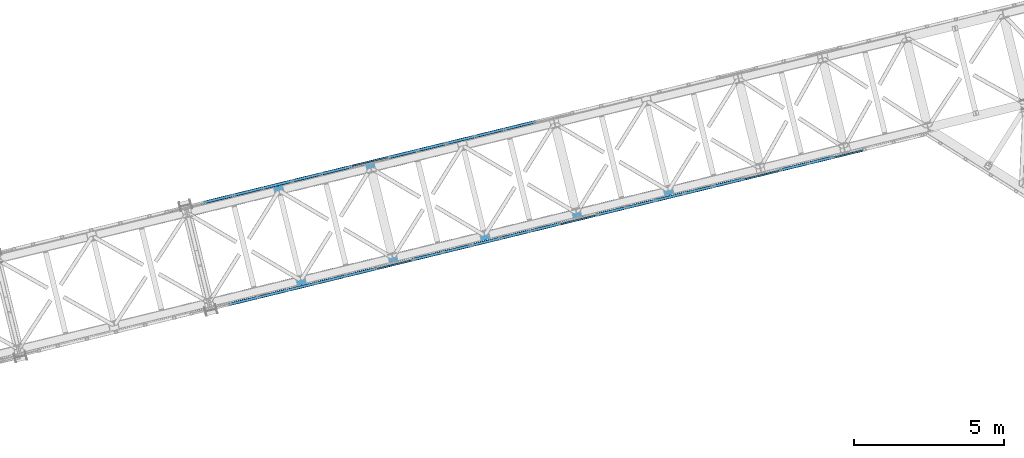
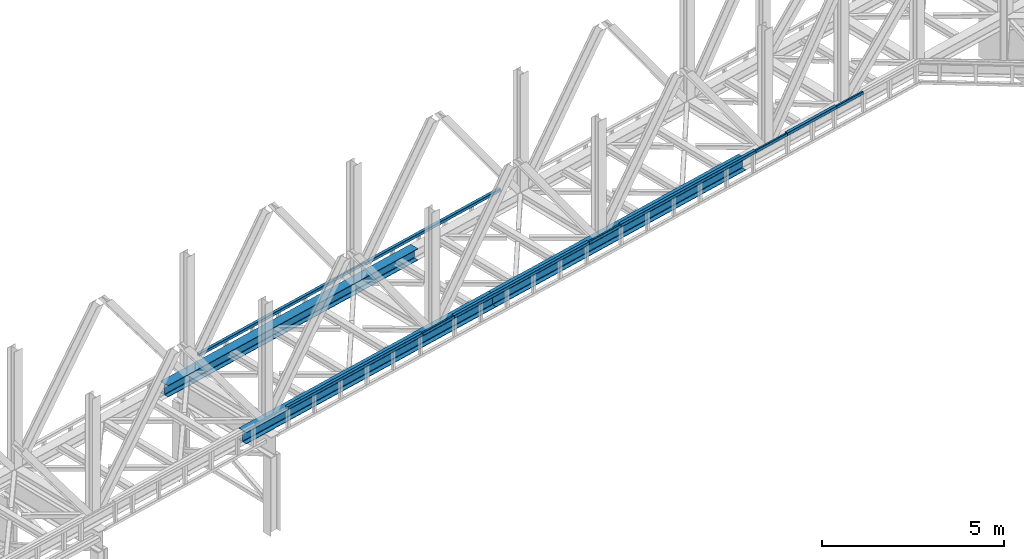
# One storey, part 18 of 93: 14 beams.
"""IFC4 building model written with IfcOpenShell, lengths in millimetres."""

import ifcopenshell
import ifcopenshell.guid

model = None  # the IFC model being written
_history = None  # IfcOwnerHistory: only IFC2X3 demands one
_inside = {}  # id of a spatial element -> (the spatial element, [elements in it])
_under = {}  # id of a project, library or spatial element -> (it, [spatial elements below it])
_declared = {}  # id of a project -> (the project, [libraries it declares])
_typed = {}  # id of a type object -> (the type object, [elements of that type])
_made_of = {}  # id of a material, layer set ... -> (it, [elements and type objects made of it])


def new_model(schema):
    """Start an empty IFC model of exactly this schema.

    Asked for "IFC4X3", IfcOpenShell would pick the latest addendum, in which some entities
    have other attributes; the version numbers below select the first issue.
    IFC2X3 requires an IfcOwnerHistory on every rooted entity: one is made here for all.
    """
    global model, _history
    if schema == "IFC4X3":
        model = ifcopenshell.file(schema_version=(4, 3, 0, 0))
    else:
        model = ifcopenshell.file(schema=schema)
    _inside.clear()
    _under.clear()
    _declared.clear()
    _typed.clear()
    _made_of.clear()
    _history = None
    if model.schema == "IFC2X3":
        org = make("IfcOrganization", Name="unknown")
        user = make(
            "IfcPersonAndOrganization",
            ThePerson=make("IfcPerson", FamilyName="unknown"),
            TheOrganization=org,
        )
        app = make(
            "IfcApplication",
            ApplicationDeveloper=org,
            Version="unknown",
            ApplicationFullName="unknown",
            ApplicationIdentifier="unknown",
        )
        _history = make(
            "IfcOwnerHistory",
            OwningUser=user,
            OwningApplication=app,
            ChangeAction="ADDED",
            CreationDate=0,
        )
    return model


def make(cls, **values):
    """One entity of the class cls with the attributes given. An attribute that is None is left unset."""
    return model.create_entity(
        cls, **{name: value for name, value in values.items() if value is not None}
    )


def entity(cls, *values):
    """Any entity or typed value of the class cls, its attributes in the order of the schema. None: left unset."""
    e = model.create_entity(cls)
    for i, value in enumerate(values):
        if value is not None:
            e[i] = value
    return e


def rooted(cls, **values):
    """An entity with a GlobalId (a new one), such as an element, a storey or a relation."""
    return make(cls, GlobalId=ifcopenshell.guid.new(), OwnerHistory=_history, **values)


def si_unit(unit_type, name, prefix=None):
    """IfcSIUnit, for example si_unit("LENGTHUNIT", "METRE", prefix="MILLI")."""
    return make("IfcSIUnit", UnitType=unit_type, Prefix=prefix, Name=name)


def converted_unit(unit_type, name, factor, base, dimensions=None, offset=None):
    """IfcConversionBasedUnit, such as the inch: factor (a typed value) times the base unit."""
    return make(
        "IfcConversionBasedUnit"
        if offset is None
        else "IfcConversionBasedUnitWithOffset",
        ConversionOffset=offset,
        Dimensions=None
        if dimensions is None
        else entity("IfcDimensionalExponents", *dimensions),
        UnitType=unit_type,
        Name=name,
        ConversionFactor=make(
            "IfcMeasureWithUnit", ValueComponent=factor, UnitComponent=base
        ),
    )


def derived_unit(unit_type, elements):
    """IfcDerivedUnit: a product of units, each with its exponent."""
    return make(
        "IfcDerivedUnit",
        Elements=[
            make("IfcDerivedUnitElement", Unit=unit, Exponent=power)
            for unit, power in elements
        ],
        UnitType=unit_type,
    )


def assignment(units):
    """IfcUnitAssignment: the units of a project."""
    return None if units is None else make("IfcUnitAssignment", Units=units)


def point(xyz):
    """IfcCartesianPoint."""
    return None if xyz is None else make("IfcCartesianPoint", Coordinates=xyz)


def direction(xyz):
    """IfcDirection."""
    return None if xyz is None else make("IfcDirection", DirectionRatios=xyz)


def frame(location, z_axis=None, x_axis=None):
    """IfcAxis2Placement3D, a coordinate frame: its origin and axes. An axis left out is left unset."""
    return make(
        "IfcAxis2Placement3D",
        Location=point(location),
        Axis=direction(z_axis),
        RefDirection=direction(x_axis),
    )


def origin():
    """The frame at (0, 0, 0) with its axes left unset."""
    return frame((0.0, 0.0, 0.0))


def place(relative_to, where):
    """IfcLocalPlacement: puts the frame where relative to a parent placement (None: the world)."""
    return make(
        "IfcLocalPlacement", PlacementRelTo=relative_to, RelativePlacement=where
    )


def context(
    kind, dimensions, precision=None, world=None, true_north=None, identifier=None
):
    """IfcGeometricRepresentationContext, for example the 3D "Model" context."""
    return make(
        "IfcGeometricRepresentationContext",
        ContextIdentifier=identifier,
        ContextType=kind,
        CoordinateSpaceDimension=dimensions,
        Precision=precision,
        WorldCoordinateSystem=world,
        TrueNorth=true_north,
    )


def subcontext(parent, identifier, kind, view, scale=None):
    """IfcGeometricRepresentationSubContext, for example "Body" below "Model"."""
    return make(
        "IfcGeometricRepresentationSubContext",
        ContextIdentifier=identifier,
        ContextType=kind,
        ParentContext=parent,
        TargetScale=scale,
        TargetView=view,
    )


def project(units=None, contexts=None):
    """IfcProject with its units and contexts."""
    return rooted(
        "IfcProject",
        Name="project",
        RepresentationContexts=contexts,
        UnitsInContext=assignment(units),
    )


def spatial(cls, under=None, at=None, **own):
    """A site, building, storey or space (cls), placed at a placement, below another one or the project."""
    s = rooted(cls, ObjectPlacement=at, **own)
    if under is not None:
        _under.setdefault(under.id(), (under, []))[1].append(s)
    return s


def point_list(points):
    """IfcCartesianPointList2D or 3D."""
    cls = (
        "IfcCartesianPointList2D" if len(points[0]) == 2 else "IfcCartesianPointList3D"
    )
    return make(cls, CoordList=points)


def indexed_curve(points, segments=None, self_intersect=None):
    """IfcIndexedPolyCurve: lines and arcs through numbered points (the first is 1)."""
    return make(
        "IfcIndexedPolyCurve",
        Points=point_list(points),
        Segments=segments,
        SelfIntersect=self_intersect,
    )


def outline(outer, holes=None, kind="AREA"):
    """IfcArbitraryClosedProfileDef: a profile drawn as a closed curve; with holes, ...WithVoids."""
    if holes is None:
        return make("IfcArbitraryClosedProfileDef", ProfileType=kind, OuterCurve=outer)
    return make(
        "IfcArbitraryProfileDefWithVoids",
        ProfileType=kind,
        OuterCurve=outer,
        InnerCurves=holes,
    )


def extrude(swept, where, along, depth):
    """IfcExtrudedAreaSolid: the profile swept, set in the frame where, extruded along a direction by depth."""
    return make(
        "IfcExtrudedAreaSolid",
        SweptArea=swept,
        Position=where,
        ExtrudedDirection=direction(along),
        Depth=depth,
    )


def shape(context_of_items, identifier, shape_type, items):
    """IfcShapeRepresentation: the items that make up one representation, for example the "Body"."""
    return make(
        "IfcShapeRepresentation",
        ContextOfItems=context_of_items,
        RepresentationIdentifier=identifier,
        RepresentationType=shape_type,
        Items=items,
    )


def material(Name=None, Category=None):
    """IfcMaterial."""
    return make("IfcMaterial", Name=Name, Category=Category)


def made_of(thing, what):
    """Note that an element or type object is made of a material, layer set ...; save() writes the relation."""
    if what is not None:
        _made_of.setdefault(what.id(), (what, []))[1].append(thing)
    return thing


def type_object(cls, material=None, **own):
    """A type object (cls), such as IfcWallType, which elements share."""
    return made_of(rooted(cls, **own), material)


def element(
    cls,
    number,
    at=None,
    inside=None,
    cuts=None,
    type_object=None,
    material=None,
    context=None,
    identifier="Body",
    shape_type=None,
    held_by="IfcProductDefinitionShape",
    body=None,
    shapes=None,
    **own,
):
    """One element of the class cls, such as IfcWall. Its Tag is "e" and its number.

    at: its placement. inside: the storey or other place that contains it. cuts: it is an
    opening in that element (IfcRelVoidsElement). A single representation is given by context,
    identifier, shape_type and body (its items); several are given by shapes. held_by: the class
    of the entity that holds the representations. save() writes the other relations.
    """
    e = rooted(cls, Tag="e%d" % number, ObjectPlacement=at, **own)
    if body is not None:
        shapes = [shape(context, identifier, shape_type, body)]
    if shapes is not None:
        e.Representation = make(held_by, Representations=shapes)
    if inside is not None:
        _inside.setdefault(inside.id(), (inside, []))[1].append(e)
    if cuts is not None:
        rooted(
            "IfcRelVoidsElement", RelatingBuildingElement=cuts, RelatedOpeningElement=e
        )
    if type_object is not None:
        _typed.setdefault(type_object.id(), (type_object, []))[1].append(e)
    return made_of(e, material)


def aggregate(whole, parts):
    """IfcRelAggregates: a whole, such as a stair, and the parts it consists of."""
    return rooted("IfcRelAggregates", RelatingObject=whole, RelatedObjects=parts)


def save(model, path):
    """Write the relations noted so far, then the file.

    IfcRelAggregates (storeys below a building ...), IfcRelContainedInSpatialStructure (elements
    in a storey), IfcRelDefinesByType, IfcRelAssociatesMaterial and IfcRelDeclares: one each for
    every whole, place, type object, material and project.
    """
    for whole, parts in _under.values():
        aggregate(whole, parts)
    for where, things in _inside.values():
        rooted(
            "IfcRelContainedInSpatialStructure",
            RelatedElements=things,
            RelatingStructure=where,
        )
    for kind, things in _typed.values():
        rooted("IfcRelDefinesByType", RelatedObjects=things, RelatingType=kind)
    for what, things in _made_of.values():
        rooted("IfcRelAssociatesMaterial", RelatedObjects=things, RelatingMaterial=what)
    for by, libraries in _declared.values():
        rooted("IfcRelDeclares", RelatingContext=by, RelatedDefinitions=libraries)
    model.write(path)


model = new_model("IFC4")

# Units and contexts
model_context = context("Model", 3, precision=0.01, world=origin(), true_north=direction((6.12303176911189e-17, 1.0)))
plan_context = context("Plan", 3, precision=0.01, world=origin(), true_north=direction((6.12303176911189e-17, 1.0)))
body_context = subcontext(model_context, "Body", "Model", "MODEL_VIEW")
ifc_project = project(units=[si_unit("LENGTHUNIT", "METRE", prefix="MILLI"), si_unit("AREAUNIT", "SQUARE_METRE"), si_unit("VOLUMEUNIT", "CUBIC_METRE"), converted_unit("PLANEANGLEUNIT", "DEGREE", entity("IfcRatioMeasure", 0.0174532925199433), si_unit("PLANEANGLEUNIT", "RADIAN"), dimensions=[0, 0, 0, 0, 0, 0, 0]), si_unit("MASSUNIT", "GRAM", prefix="KILO"), derived_unit("MASSDENSITYUNIT", [(si_unit("MASSUNIT", "GRAM", prefix="KILO"), 1), (si_unit("LENGTHUNIT", "METRE"), -3)]), derived_unit("MOMENTOFINERTIAUNIT", [(si_unit("LENGTHUNIT", "METRE"), 4)]), si_unit("TIMEUNIT", "SECOND"), si_unit("FREQUENCYUNIT", "HERTZ"), si_unit("THERMODYNAMICTEMPERATUREUNIT", "DEGREE_CELSIUS"), derived_unit("THERMALTRANSMITTANCEUNIT", [(si_unit("MASSUNIT", "GRAM", prefix="KILO"), 1), (si_unit("THERMODYNAMICTEMPERATUREUNIT", "KELVIN"), -1), (si_unit("TIMEUNIT", "SECOND"), -3)]), derived_unit("VOLUMETRICFLOWRATEUNIT", [(si_unit("LENGTHUNIT", "METRE"), 3), (si_unit("TIMEUNIT", "SECOND"), -1)]), derived_unit("MASSFLOWRATEUNIT", [(si_unit("MASSUNIT", "GRAM", prefix="KILO"), 1), (si_unit("TIMEUNIT", "SECOND"), -1)]), derived_unit("ROTATIONALFREQUENCYUNIT", [(si_unit("TIMEUNIT", "SECOND"), -1)]), si_unit("ELECTRICCURRENTUNIT", "AMPERE"), si_unit("ELECTRICVOLTAGEUNIT", "VOLT"), si_unit("POWERUNIT", "WATT"), si_unit("FORCEUNIT", "NEWTON", prefix="KILO"), si_unit("ILLUMINANCEUNIT", "LUX"), si_unit("LUMINOUSFLUXUNIT", "LUMEN"), si_unit("LUMINOUSINTENSITYUNIT", "CANDELA"), derived_unit("USERDEFINED", [(si_unit("MASSUNIT", "GRAM", prefix="KILO"), -1), (si_unit("LENGTHUNIT", "METRE"), -2), (si_unit("TIMEUNIT", "SECOND"), 3), (si_unit("LUMINOUSFLUXUNIT", "LUMEN"), 1)]), derived_unit("LINEARVELOCITYUNIT", [(si_unit("LENGTHUNIT", "METRE"), 1), (si_unit("TIMEUNIT", "SECOND"), -1)]), si_unit("PRESSUREUNIT", "PASCAL"), derived_unit("USERDEFINED", [(si_unit("LENGTHUNIT", "METRE"), -2), (si_unit("MASSUNIT", "GRAM", prefix="KILO"), 1), (si_unit("TIMEUNIT", "SECOND"), -2)]), derived_unit("LINEARFORCEUNIT", [(si_unit("MASSUNIT", "GRAM", prefix="KILO"), 1), (si_unit("LENGTHUNIT", "METRE"), 1), (si_unit("TIMEUNIT", "SECOND"), -2), (si_unit("LENGTHUNIT", "METRE"), -1)]), derived_unit("PLANARFORCEUNIT", [(si_unit("MASSUNIT", "GRAM", prefix="KILO"), 1), (si_unit("LENGTHUNIT", "METRE"), 1), (si_unit("TIMEUNIT", "SECOND"), -2), (si_unit("LENGTHUNIT", "METRE"), -2)])], contexts=[model_context, plan_context])

# Site, building, storey
site_placement = place(None, origin())
site = spatial("IfcSite", under=ifc_project, at=site_placement, CompositionType="ELEMENT")
building_placement = place(site_placement, origin())
building = spatial("IfcBuilding", under=site, at=building_placement, CompositionType="ELEMENT")
storey_placement = place(building_placement, frame((0.0, 0.0, 15900.0)))
storey = spatial("IfcBuildingStorey", under=building, at=storey_placement, CompositionType="ELEMENT", Elevation=15900.0)

# Beams
ifc_material = material(Name="Metal painted (White)")
beam_type = type_object("IfcBeamType", PredefinedType="BEAM")
beam_1_placement = place(storey_placement, origin())
element("IfcBeam", 1, at=beam_1_placement, inside=storey, type_object=beam_type, material=ifc_material, ObjectType="Steel Beam", PredefinedType="BEAM", context=body_context, shape_type="SweptSolid", body=[
    extrude(outline(indexed_curve([(-195.999999999999, -150.000000000005), (-179.999999999996, -150.000000000005), (-179.999999999996, -27.7500000000041), (-178.325349715245, -19.3309644879734), (-173.556349186101, -12.1936508138996), (-166.419035512029, -7.42465028475491), (-157.999999999997, -5.75000000000425), (158.000000000005, -5.75000000000425), (166.419035512033, -7.42465028475491), (173.556349186107, -12.1936508138996), (178.325349715251, -19.3309644879734), (180.0, -27.7500000000041), (180.0, -150.000000000005), (196.000000000005, -150.000000000005), (196.000000000005, 149.999999999996), (180.0, 149.999999999996), (180.0, 27.7499999999947), (178.325349715251, 19.3309644879649), (173.556349186107, 12.1936508138912), (166.419035512033, 7.42465028474757), (158.000000000005, 5.74999999999584), (-157.999999999997, 5.74999999999373), (-166.419035512029, 7.42465028474757), (-173.556349186101, 12.1936508138912), (-178.325349715245, 19.3309644879618), (-179.999999999996, 27.7499999999968), (-179.999999999996, 149.999999999994), (-195.999999999999, 149.999999999996), (-195.999999999999, -150.000000000005)], self_intersect=False)), frame((-30278.9740146601, 10220.7567522767, 3489.0), z_axis=(0.971552058141469, 0.236826092990355, 0.0), x_axis=(0.0, 0.0, 1.0)), (0.0, 0.0, 1.0), 9480.00000000004),
])
beam_2_placement = place(storey_placement, origin())
element("IfcBeam", 2, at=beam_2_placement, inside=storey, type_object=beam_type, material=ifc_material, ObjectType="Steel Beam", PredefinedType="BEAM", context=body_context, shape_type="SweptSolid", body=[
    extrude(outline(indexed_curve([(-195.999999999999, -150.000000000003), (-179.999999999996, -150.000000000003), (-179.999999999996, -27.750000000002), (-178.325349715245, -19.3309644879713), (-173.556349186101, -12.1936508138975), (-166.419035512029, -7.4246502847528), (-157.999999999997, -5.75000000000215), (158.000000000005, -5.75000000000215), (166.419035512033, -7.4246502847528), (173.556349186107, -12.1936508138975), (178.325349715251, -19.3309644879713), (180.0, -27.750000000002), (180.0, -150.000000000003), (196.000000000005, -150.000000000003), (196.000000000005, 149.999999999996), (180.0, 149.999999999996), (180.0, 27.7499999999947), (178.325349715251, 19.330964487967), (173.556349186107, 12.1936508138912), (166.419035512033, 7.42465028474967), (158.000000000005, 5.74999999999584), (-157.999999999997, 5.74999999999584), (-166.419035512029, 7.42465028474967), (-173.556349186101, 12.1936508138933), (-178.325349715245, 19.330964487967), (-179.999999999996, 27.7499999999999), (-179.999999999996, 149.999999999996), (-195.999999999999, 149.999999999996), (-195.999999999999, -150.000000000003)], self_intersect=False)), frame((-21068.6605034789, 12465.8681138251, 3489.0), z_axis=(0.971552058141469, 0.236826092990355, 0.0), x_axis=(0.0, 0.0, 1.0)), (0.0, 0.0, 1.0), 9479.99999999997),
])
beam_3_placement = place(storey_placement, origin())
element("IfcBeam", 3, at=beam_3_placement, inside=storey, type_object=beam_type, material=ifc_material, ObjectType="Steel Beam", PredefinedType="BEAM", context=body_context, shape_type="SweptSolid", body=[
    extrude(outline(indexed_curve([(-195.999999999999, -150.000000000001), (-179.999999999996, -150.000000000001), (-179.999999999996, -27.7499999999999), (-178.325349715245, -19.3309644879691), (-173.556349186101, -12.1936508138954), (-166.419035512029, -7.4246502847528), (-157.999999999997, -5.75000000000005), (158.000000000005, -5.75000000000005), (166.419035512033, -7.4246502847528), (173.556349186107, -12.1936508138954), (178.325349715251, -19.3309644879691), (180.0, -27.7499999999999), (180.0, -150.000000000001), (196.000000000005, -150.000000000001), (196.000000000005, 149.999999999998), (180.0, 149.999999999998), (180.0, 27.7499999999968), (178.325349715251, 19.3309644879691), (173.556349186107, 12.1936508138933), (166.419035512033, 7.4246502847528), (158.000000000005, 5.74999999999794), (-157.999999999997, 5.74999999999584), (-166.419035512029, 7.42465028474757), (-173.556349186101, 12.1936508138933), (-178.325349715247, 19.330964487967), (-179.999999999996, 27.7499999999968), (-179.999999999996, 149.999999999996), (-195.999999999999, 149.999999999998), (-195.999999999999, -150.000000000001)], self_intersect=False)), frame((-31013.1349029302, 13232.5681325153, 3489.0), z_axis=(0.971552058141469, 0.236826092990355, 0.0), x_axis=(0.0, 0.0, 1.0)), (0.0, 0.0, 1.0), 9480.00000000004),
])
beam_4_placement = place(storey_placement, origin())
element("IfcBeam", 4, at=beam_4_placement, inside=storey, type_object=beam_type, material=ifc_material, ObjectType="Steel Beam", PredefinedType="BEAM", context=body_context, shape_type="SweptSolid", body=[
    extrude(outline(indexed_curve([(29.4768951153319, -56.8428769008003), (33.3787015556544, -56.8428769008003), (36.9835006656888, -55.3497202197897), (39.7424944585191, -52.5907264269642), (41.2356511395258, -48.9859273169303), (56.8428769008051, 29.4768951153294), (56.8428769008049, 33.3787015556509), (55.3497202197946, 36.9835006656864), (52.5907264269671, 39.7424944585227), (48.9859273169311, 41.2356511395243), (-29.476895115329, 56.8428769008041), (-33.3787015556507, 56.8428769008084), (-36.9835006656858, 55.3497202197935), (-39.742494458517, 52.5907264269638), (-41.2356511395237, 48.9859273169299), (-56.8428769008031, -29.4768951153298), (-56.8428769008019, -33.3787015556515), (-55.3497202197906, -36.9835006656828), (-52.5907264269633, -39.7424944585146), (-48.9859273169282, -41.2356511395205), (29.4768951153319, -56.8428769008003)], self_intersect=False), holes=[indexed_curve([(-50.9634988887046, -25.5484203233951), (-37.3071763475817, 43.1065493048336), (-35.8140196665771, 46.7113484148679), (-33.0550258737489, 49.4703422076983), (-29.4502267637103, 50.9634988887036), (-25.5484203233909, 50.9634988887042), (43.1065493048361, 37.3071763475801), (46.7113484148721, 35.8140196665785), (49.4703422077023, 33.0550258737505), (50.9634988887086, 29.4502267637158), (50.9634988887087, 25.5484203233943), (37.3071763475889, -43.1065493048351), (35.8140196665843, -46.7113484148694), (33.055025873758, -49.4703422076957), (29.4502267637217, -50.9634988887059), (25.5484203233971, -50.9634988887055), (-43.1065493048287, -37.307176347586), (-46.7113484148688, -35.8140196665836), (-49.4703422076953, -33.0550258737475), (-50.9634988887024, -29.450226763717), (-50.9634988887046, -25.5484203233951)], self_intersect=False)]), frame((-23487.2518283155, 15272.9379390032, 3830.0), z_axis=(0.971552058141621, 0.236826092989728, 0.0), x_axis=(0.232275546019843, -0.952883957770766, -0.195090322015997)), (0.0, 0.0, 1.0), 5120.00000000002),
])
beam_5_placement = place(storey_placement, origin())
element("IfcBeam", 5, at=beam_5_placement, inside=storey, type_object=beam_type, material=ifc_material, ObjectType="Steel Beam", PredefinedType="BEAM", context=body_context, shape_type="SweptSolid", body=[
    extrude(outline(indexed_curve([(29.4768951153935, -56.8428769007593), (33.3787015557151, -56.8428769007593), (36.983500665747, -55.349720219749), (39.742494458576, -52.590726426912), (41.2356511395787, -48.9859273168765), (56.8428769007747, 29.4768951153998), (56.8428769007672, 33.378701555722), (55.3497202197551, 36.983500665751), (52.5907264269217, 39.7424944585804), (48.985927316885, 41.2356511395824), (-29.4768951153901, 56.8428769007763), (-33.3787015557126, 56.842876900772), (-36.9835006657444, 55.3497202197617), (-39.7424944585747, 52.5907264269294), (-41.2356511395753, 48.9859273168935), (-56.8428769007713, -29.4768951153829), (-56.8428769007638, -33.378701555705), (-55.3497202197535, -36.9835006657425), (-52.5907264269192, -39.7424944585677), (-48.9859273168817, -41.2356511395654), (29.4768951153935, -56.8428769007593)], self_intersect=False), holes=[indexed_curve([(-50.9634988886751, -25.5484203234422), (-37.307176347631, 43.1065493048023), (-35.8140196666262, 46.7113484148374), (-33.055025873804, 49.4703422076669), (-29.4502267637722, 50.9634988886772), (-25.5484203234488, 50.9634988886857), (43.106549304796, 37.3071763476402), (46.7113484148319, 35.8140196666341), (49.470342207663, 33.0550258738095), (50.9634988886761, 29.4502267637803), (50.9634988886805, 25.5484203234587), (37.3071763476375, -43.1065493047859), (35.8140196666368, -46.7113484148218), (33.0550258738057, -49.4703422076584), (29.4502267637718, -50.9634988886683), (25.5484203234514, -50.963498888673), (-43.1065493047935, -37.3071763476275), (-46.7113484148302, -35.8140196666256), (-49.4703422076655, -33.0550258738002), (-50.9634988886707, -29.4502267637637), (-50.9634988886751, -25.5484203234422)], self_intersect=False)]), frame((-29627.4608357696, 13776.1970313043, 3830.0), z_axis=(0.971552058141621, 0.236826092989728, 0.0), x_axis=(0.232275546019893, -0.952883957770972, -0.19509032201493)), (0.0, 0.0, 1.0), 5119.99999999998),
])
beam_6_placement = place(storey_placement, origin())
element("IfcBeam", 6, at=beam_6_placement, inside=storey, type_object=beam_type, material=ifc_material, ObjectType="Steel Beam", PredefinedType="BEAM", context=body_context, shape_type="SweptSolid", body=[
    extrude(outline(indexed_curve([(9.86118950714156, -52.9410704605108), (13.7629959474637, -52.9410704605108), (17.3677950575018, -51.4479137795173), (20.1267888503371, -48.688919986689), (21.619945531354, -45.0841208766589), (37.2271712928117, 33.3787015555653), (37.2271712928194, 37.280507995887), (35.7340146118204, 40.8853071059253), (32.9750208189955, 43.6443008987598), (29.3702217089667, 45.1374575797777), (-9.8611895071486, 52.9410704605078), (-13.7629959474699, 52.941070460512), (-17.3677950575068, 51.4479137795139), (-20.1267888503412, 48.6889199866898), (-21.6199455313581, 45.0841208766597), (-37.2271712928179, -33.3787015555641), (-37.2271712928236, -37.2805079958862), (-35.7340146118264, -40.8853071059285), (-32.9750208190027, -43.6443008987584), (-29.3702217089748, -45.1374575797806), (9.86118950714156, -52.9410704605108)], self_intersect=False), holes=[indexed_curve([(-31.3477932807115, -29.4502267636426), (-17.6914707394336, 39.2047428645554), (-16.1983140584188, 42.8095419745858), (-13.4393202655864, 45.5685357674103), (-9.83452115554951, 47.0616924484085), (-5.93271471522702, 47.0616924483995), (23.4908436968574, 41.2089827878524), (27.0956428068891, 39.7158261068383), (29.854636599712, 36.9568323140043), (31.3477932807151, 33.3520332039651), (31.3477932807074, 29.4502267636434), (17.6914707394295, -39.2047428645545), (16.1983140584126, -42.8095419745846), (13.4393202655773, -45.5685357674129), (9.83452115554126, -47.0616924484068), (5.93271471521876, -47.0616924483979), (-23.4908436968687, -41.2089827878502), (-27.0956428068983, -39.7158261068365), (-29.85463659972, -36.9568323140071), (-31.3477932807192, -33.3520332039643), (-31.3477932807115, -29.4502267636426)], self_intersect=False)]), frame((-24657.5843905905, 15007.0846725123, 3830.0), z_axis=(0.97155205814156, 0.236826092989979, 0.0), x_axis=(-0.232275546019865, 0.952883957770302, 0.195090322018236)), (0.0, 0.0, 1.0), 1200.00000000001),
])
beam_7_placement = place(storey_placement, origin())
element("IfcBeam", 7, at=beam_7_placement, inside=storey, type_object=beam_type, material=ifc_material, ObjectType="Steel Beam", PredefinedType="BEAM", context=body_context, shape_type="SweptSolid", body=[
    extrude(outline(indexed_curve([(29.4768951153359, -56.8428769008), (33.3787015556589, -56.8428769008), (36.9835006656937, -55.3497202197894), (39.7424944585219, -52.5907264269634), (41.2356511395285, -48.9859273169295), (56.8428769008057, 29.4768951153306), (56.8428769008063, 33.3787015556564), (55.3497202197999, 36.9835006656911), (52.5907264269695, 39.7424944585234), (48.9859273169335, 41.235651139525), (-29.4768951153284, 56.8428769008029), (-33.3787015556505, 56.8428769008072), (-36.9835006656853, 55.3497202197966), (-39.7424944585123, 52.5907264269659), (-41.2356511395197, 48.9859273169278), (-56.842876900797, -29.4768951153324), (-56.8428769007967, -33.3787015556539), (-55.3497202197895, -36.9835006656843), (-52.590726426959, -39.7424944585167), (-48.9859273169239, -41.2356511395224), (29.4768951153359, -56.8428769008)], self_intersect=False), holes=[indexed_curve([(-50.9634988886993, -25.548420323393), (-37.3071763475822, 43.1065493048325), (-35.8140196665777, 46.7113484148669), (-33.0550258737465, 49.4703422076967), (-29.4502267637117, 50.9634988887073), (-25.5484203233887, 50.9634988887073), (43.1065493048367, 37.3071763475898), (46.7113484148703, 35.8140196665843), (49.4703422077049, 33.0550258737511), (50.9634988887112, 29.4502267637165), (50.9634988887089, 25.5484203233955), (37.3071763475943, -43.1065493048305), (35.8140196665864, -46.7113484148686), (33.0550258737603, -49.470342207695), (29.4502267637234, -50.9634988887052), (25.5484203234004, -50.9634988887052), (-43.1065493048271, -37.3071763475873), (-46.7113484148636, -35.8140196665857), (-49.4703422076906, -33.0550258737496), (-50.9634988886999, -29.4502267637187), (-50.9634988886993, -25.548420323393)], self_intersect=False)]), frame((-10375.8110531042, 14857.2435823827, 3830.0), z_axis=(0.971552058141501, 0.236826092990222, 0.0), x_axis=(0.232275546020368, -0.952883957770643, -0.195090322015972)), (0.0, 0.0, 1.0), 1879.99999999999),
])
beam_8_placement = place(storey_placement, origin())
element("IfcBeam", 8, at=beam_8_placement, inside=storey, type_object=beam_type, material=ifc_material, ObjectType="Steel Beam", PredefinedType="BEAM", context=body_context, shape_type="SweptSolid", body=[
    extrude(outline(indexed_curve([(29.4768951153333, -56.8428769007995), (33.3787015556563, -56.8428769007995), (36.9835006656911, -55.3497202197889), (39.7424944585193, -52.5907264269629), (41.2356511395264, -48.9859273169291), (56.8428769008031, 29.4768951153312), (56.8428769008029, 33.3787015556527), (55.349720219795, 36.9835006656876), (52.5907264269674, 39.7424944585238), (48.9859273169314, 41.2356511395254), (-29.4768951153304, 56.8428769008034), (-33.3787015556505, 56.8428769008072), (-36.9835006656882, 55.3497202197927), (-39.7424944585173, 52.5907264269625), (-41.2356511395223, 48.9859273169283), (-56.8428769008011, -29.4768951153316), (-56.8428769007987, -33.3787015556535), (-55.3497202197916, -36.9835006656839), (-52.5907264269611, -39.7424944585163), (-48.985927316928, -41.2356511395216), (29.4768951153333, -56.8428769007995)], self_intersect=False), holes=[indexed_curve([(-50.9634988887069, -25.5484203233959), (-37.3071763475868, 43.1065493048334), (-35.8140196665818, 46.7113484148677), (-33.0550258737507, 49.4703422076975), (-29.4502267637167, 50.9634988887039), (-25.5484203233958, 50.9634988887043), (43.1065493048318, 37.3071763475864), (46.7113484148694, 35.8140196665801), (49.4703422076982, 33.0550258737525), (50.9634988887045, 29.4502267637178), (50.9634988887069, 25.5484203233959), (37.3071763475868, -43.1065493048334), (35.8140196665843, -46.7113484148682), (33.0550258737561, -49.4703422076942), (29.4502267637167, -50.9634988887039), (25.5484203233958, -50.9634988887043), (-43.1065493048338, -37.307176347586), (-46.7113484148698, -35.8140196665844), (-49.4703422076973, -33.0550258737482), (-50.9634988887045, -29.4502267637178), (-50.9634988887069, -25.5484203233959)], self_intersect=False)]), frame((-16516.0200605582, 13360.5026746838, 3830.0), z_axis=(0.971552058141501, 0.236826092990222, 0.0), x_axis=(0.232275546020368, -0.952883957770643, -0.195090322015972)), (0.0, 0.0, 1.0), 5119.99999999996),
])
beam_9_placement = place(storey_placement, origin())
element("IfcBeam", 9, at=beam_9_placement, inside=storey, type_object=beam_type, material=ifc_material, ObjectType="Steel Beam", PredefinedType="BEAM", context=body_context, shape_type="SweptSolid", body=[
    extrude(outline(indexed_curve([(29.476895115334, -56.8428769008007), (33.3787015556565, -56.8428769008007), (36.9835006656908, -55.3497202197901), (39.7424944585191, -52.5907264269642), (41.2356511395258, -48.9859273169303), (56.8428769008051, 29.4768951153294), (56.8428769008049, 33.3787015556509), (55.3497202197966, 36.983500665686), (52.5907264269691, 39.7424944585223), (48.9859273169332, 41.2356511395239), (-29.476895115329, 56.8428769008041), (-33.3787015556486, 56.842876900808), (-36.9835006656858, 55.3497202197935), (-39.742494458515, 52.5907264269634), (-41.2356511395216, 48.9859273169295), (-56.8428769008, -29.4768951153304), (-56.8428769007998, -33.3787015556519), (-55.3497202197906, -36.9835006656828), (-52.5907264269612, -39.742494458515), (-48.9859273169282, -41.2356511395205), (29.476895115334, -56.8428769008007)], self_intersect=False), holes=[indexed_curve([(-50.9634988887025, -25.5484203233955), (-37.3071763475817, 43.1065493048336), (-35.814019666575, 46.7113484148675), (-33.0550258737469, 49.4703422076979), (-29.4502267637134, 50.9634988887043), (-25.5484203233909, 50.9634988887042), (43.106549304837, 37.3071763475844), (46.7113484148721, 35.8140196665785), (49.4703422077054, 33.0550258737499), (50.9634988887086, 29.4502267637158), (50.9634988887087, 25.5484203233943), (37.3071763475909, -43.1065493048355), (35.8140196665843, -46.7113484148694), (33.055025873758, -49.4703422076957), (29.4502267637196, -50.9634988887055), (25.5484203233971, -50.9634988887055), (-43.1065493048308, -37.3071763475856), (-46.7113484148637, -35.8140196665846), (-49.4703422076953, -33.0550258737475), (-50.9634988887024, -29.450226763717), (-50.9634988887025, -25.5484203233955)], self_intersect=False)]), frame((-22656.2290680124, 11863.7617669848, 3830.0), z_axis=(0.971552058141621, 0.236826092989728, 0.0), x_axis=(0.232275546019843, -0.952883957770766, -0.195090322015997)), (0.0, 0.0, 1.0), 5120.00000000002),
])
beam_10_placement = place(storey_placement, origin())
element("IfcBeam", 10, at=beam_10_placement, inside=storey, type_object=beam_type, material=ifc_material, ObjectType="Steel Beam", PredefinedType="BEAM", context=body_context, shape_type="SweptSolid", body=[
    extrude(outline(indexed_curve([(29.4768951153935, -56.8428769007593), (33.3787015557151, -56.8428769007593), (36.983500665747, -55.349720219749), (39.742494458576, -52.590726426912), (41.2356511395787, -48.9859273168765), (56.8428769007726, 29.4768951154003), (56.8428769007651, 33.3787015557224), (55.349720219756, 36.9835006657552), (52.5907264269217, 39.7424944585804), (48.985927316885, 41.2356511395824), (-29.4768951153921, 56.8428769007767), (-33.3787015557126, 56.842876900772), (-36.9835006657473, 55.3497202197579), (-39.7424944585747, 52.5907264269294), (-41.2356511395753, 48.9859273168935), (-56.8428769007713, -29.4768951153829), (-56.8428769007638, -33.378701555705), (-55.3497202197555, -36.9835006657421), (-52.5907264269192, -39.7424944585677), (-48.9859273168837, -41.235651139565), (29.4768951153935, -56.8428769007593)], self_intersect=False), holes=[indexed_curve([(-50.9634988886772, -25.5484203234418), (-37.3071763476341, 43.1065493048029), (-35.8140196666262, 46.7113484148374), (-33.055025873804, 49.4703422076669), (-29.4502267637742, 50.9634988886776), (-25.5484203234488, 50.9634988886857), (43.1065493047939, 37.3071763476406), (46.7113484148319, 35.8140196666341), (49.470342207663, 33.0550258738095), (50.9634988886741, 29.4502267637807), (50.9634988886785, 25.5484203234592), (37.3071763476354, -43.1065493047855), (35.8140196666368, -46.7113484148218), (33.0550258738037, -49.470342207658), (29.4502267637718, -50.9634988886683), (25.5484203234493, -50.9634988886726), (-43.1065493047955, -37.3071763476271), (-46.7113484148281, -35.814019666626), (-49.4703422076655, -33.0550258738002), (-50.9634988886727, -29.4502267637633), (-50.9634988886772, -25.5484203234418)], self_intersect=False)]), frame((-28796.4380754665, 10367.0208592859, 3830.0), z_axis=(0.971552058141621, 0.236826092989728, 0.0), x_axis=(0.232275546019893, -0.952883957770972, -0.19509032201493)), (0.0, 0.0, 1.0), 5119.99999999998),
])
beam_11_placement = place(storey_placement, origin())
element("IfcBeam", 11, at=beam_11_placement, inside=storey, type_object=beam_type, material=ifc_material, ObjectType="Steel Beam", PredefinedType="BEAM", context=body_context, shape_type="SweptSolid", body=[
    extrude(outline(indexed_curve([(9.86118950714821, -52.94107046051), (13.7629959474724, -52.94107046051), (17.3677950575093, -51.4479137795159), (20.1267888503473, -48.6889199866879), (21.6199455313597, -45.0841208766568), (37.2271712928107, 33.3787015555687), (37.2271712928189, 37.2805079958903), (35.7340146118184, 40.8853071059286), (32.9750208189941, 43.6443008987626), (29.3702217089642, 45.1374575797804), (-9.86118950714905, 52.9410704605057), (-13.7629959474724, 52.94107046051), (-17.3677950575101, 51.4479137795116), (-20.1267888503473, 48.6889199866879), (-21.6199455313597, 45.0841208766568), (-37.2271712928107, -33.3787015555687), (-37.2271712928189, -37.2805079958903), (-35.7340146118193, -40.8853071059329), (-32.9750208189941, -43.6443008987626), (-29.370221708965, -45.1374575797846), (9.86118950714821, -52.94107046051)], self_intersect=False), holes=[indexed_curve([(-31.3477932807058, -29.4502267636464), (-17.6914707394375, 39.2047428645534), (-16.19831405842, 42.8095419745835), (-13.439320265588, 45.5685357674083), (-9.83452115555026, 47.0616924484066), (-5.93271471522776, 47.0616924483981), (23.4908436968584, 41.2089827878538), (27.0956428068872, 39.7158261068407), (29.8546365997115, 36.9568323140067), (31.347793280712, 33.3520332039684), (31.3477932807058, 29.4502267636464), (17.6914707394355, -39.204742864553), (16.19831405842, -42.8095419745835), (13.439320265583, -45.5685357674117), (9.83452115555026, -47.0616924484066), (5.9327147152257, -47.0616924483977), (-23.4908436968605, -41.2089827878534), (-27.0956428068872, -39.7158261068407), (-29.8546365997103, -36.9568323140114), (-31.3477932807141, -33.3520332039679), (-31.3477932807058, -29.4502267636464)], self_intersect=False)]), frame((-23817.621445277, 11561.232410299, 3830.0), z_axis=(0.971552058141752, 0.236826092989194, 0.0), x_axis=(-0.232275546019742, 0.952883957770353, 0.195090322018133)), (0.0, 0.0, 1.0), 1200.00000000001),
])
beam_12_placement = place(storey_placement, origin())
element("IfcBeam", 12, at=beam_12_placement, inside=storey, type_object=beam_type, material=ifc_material, ObjectType="Steel Beam", PredefinedType="BEAM", context=body_context, shape_type="SweptSolid", body=[
    extrude(outline(indexed_curve([(9.86118950714672, -52.9410704605091), (13.7629959474714, -52.9410704605091), (17.3677950575073, -51.4479137795148), (20.1267888503442, -48.6889199866865), (21.6199455313602, -45.0841208766561), (37.2271712928074, 33.3787015555702), (37.2271712928146, 37.2805079958919), (35.7340146118146, 40.8853071059301), (32.9750208189909, 43.6443008987639), (29.3702217089594, 45.1374575797819), (-9.86118950715376, 52.9410704605061), (-13.7629959474776, 52.9410704605104), (-17.3677950575143, 51.4479137795117), (-20.1267888503509, 48.6889199866878), (-21.6199455313643, 45.084120876657), (-37.2271712928121, -33.3787015555693), (-37.2271712928208, -37.2805079958907), (-35.7340146118201, -40.8853071059335), (-32.9750208189955, -43.644300898763), (-29.3702217089643, -45.1374575797853), (9.86118950714672, -52.9410704605091)], self_intersect=False), holes=[indexed_curve([(-31.3477932807062, -29.450226763647), (-17.6914707394376, 39.2047428645528), (-16.1983140584241, 42.8095419745837), (-13.4393202655922, 45.5685357674085), (-9.8345211555534, 47.0616924484067), (-5.93271471523247, 47.0616924483986), (23.4908436968547, 41.208982787855), (27.095642806887, 39.7158261068413), (29.8546365997067, 36.9568323140083), (31.3477932807108, 33.3520332039692), (31.3477932807036, 29.4502267636475), (17.6914707394355, -39.2047428645524), (16.1983140584195, -42.8095419745827), (13.4393202655846, -45.5685357674114), (9.83452115554877, -47.0616924484058), (5.93271471522577, -47.0616924483973), (-23.4908436968593, -41.2089827878541), (-27.0956428068896, -39.7158261068408), (-29.8546365997121, -36.9568323140116), (-31.3477932807129, -33.3520332039688), (-31.3477932807062, -29.450226763647)], self_intersect=False)]), frame((-17677.1460084682, 13056.8803219325, 3830.0), z_axis=(0.971552058141436, 0.236826092990489, 0.0), x_axis=(-0.232275546020267, 0.95288395777023, 0.195090322018108)), (0.0, 0.0, 1.0), 1200.00000000001),
])
beam_13_placement = place(storey_placement, origin())
element("IfcBeam", 13, at=beam_13_placement, inside=storey, type_object=beam_type, material=ifc_material, ObjectType="Steel Beam", PredefinedType="BEAM", context=body_context, shape_type="SweptSolid", body=[
    extrude(outline(indexed_curve([(9.86118950714672, -52.9410704605091), (13.7629959474714, -52.9410704605091), (17.3677950575073, -51.4479137795148), (20.1267888503442, -48.6889199866865), (21.6199455313602, -45.0841208766561), (37.2271712928074, 33.3787015555702), (37.2271712928146, 37.2805079958919), (35.7340146118146, 40.8853071059301), (32.9750208189909, 43.6443008987639), (29.3702217089594, 45.1374575797819), (-9.86118950715376, 52.9410704605061), (-13.7629959474776, 52.9410704605104), (-17.3677950575143, 51.4479137795117), (-20.1267888503509, 48.6889199866878), (-21.6199455313643, 45.084120876657), (-37.2271712928121, -33.3787015555693), (-37.2271712928208, -37.2805079958907), (-35.7340146118201, -40.8853071059335), (-32.9750208189955, -43.644300898763), (-29.3702217089643, -45.1374575797853), (9.86118950714672, -52.9410704605091)], self_intersect=False), holes=[indexed_curve([(-31.3477932807062, -29.450226763647), (-17.6914707394376, 39.2047428645528), (-16.1983140584241, 42.8095419745837), (-13.4393202655922, 45.5685357674085), (-9.8345211555534, 47.0616924484067), (-5.93271471523247, 47.0616924483986), (23.4908436968547, 41.208982787855), (27.095642806887, 39.7158261068413), (29.8546365997067, 36.9568323140083), (31.3477932807108, 33.3520332039692), (31.3477932807036, 29.4502267636475), (17.6914707394355, -39.2047428645524), (16.1983140584195, -42.8095419745827), (13.4393202655846, -45.5685357674114), (9.83452115554877, -47.0616924484058), (5.93271471522577, -47.0616924483973), (-23.4908436968593, -41.2089827878541), (-27.0956428068896, -39.7158261068408), (-29.8546365997121, -36.9568323140116), (-31.3477932807129, -33.3520332039688), (-31.3477932807062, -29.450226763647)], self_intersect=False)]), frame((-11536.9370010141, 14553.6212296314, 3830.0), z_axis=(0.971552058141436, 0.236826092990489, 0.0), x_axis=(-0.232275546020267, 0.95288395777023, 0.195090322018108)), (0.0, 0.0, 1.0), 1200.00000000001),
])
beam_14_placement = place(storey_placement, origin())
element("IfcBeam", 14, at=beam_14_placement, inside=storey, type_object=beam_type, material=ifc_material, ObjectType="Steel Beam", PredefinedType="BEAM", context=body_context, shape_type="SweptSolid", body=[
    extrude(outline(indexed_curve([(9.86118950714643, -52.9410704605091), (13.7629959474711, -52.9410704605091), (17.3677950575072, -51.4479137795148), (20.1267888503449, -48.6889199866867), (21.6199455313591, -45.0841208766559), (37.2271712928088, 33.3787015555699), (37.2271712928163, 37.2805079958916), (35.7340146118152, 40.88530710593), (32.9750208189917, 43.6443008987638), (29.3702217089602, 45.1374575797817), (-9.86118950715165, 52.9410704605057), (-13.7629959474755, 52.94107046051), (-17.3677950575124, 51.4479137795114), (-20.1267888503493, 48.6889199866875), (-21.6199455313635, 45.0841208766568), (-37.2271712928132, -33.3787015555691), (-37.2271712928186, -37.2805079958911), (-35.7340146118204, -40.8853071059334), (-32.9750208189961, -43.6443008987629), (-29.3702217089634, -45.1374575797855), (9.86118950714643, -52.9410704605091)], self_intersect=False), holes=[indexed_curve([(-31.3477932807045, -29.4502267636474), (-17.6914707394377, 39.2047428645528), (-16.1983140584235, 42.8095419745835), (-13.4393202655911, 45.5685357674083), (-9.83452115555179, 47.0616924484064), (-5.93271471523111, 47.0616924483984), (23.490843696855, 41.2089827878549), (27.0956428068874, 39.7158261068412), (29.8546365997086, 36.9568323140079), (31.347793280712, 33.352033203969), (31.3477932807045, 29.4502267636474), (17.6914707394375, -39.2047428645528), (16.1983140584212, -42.8095419745831), (13.4393202655858, -45.5685357674117), (9.83452115554973, -47.061692448406), (5.93271471522673, -47.0616924483975), (-23.4908436968574, -41.2089827878545), (-27.0956428068897, -39.7158261068407), (-29.8546365997117, -36.9568323140117), (-31.347793280712, -33.352033203969), (-31.3477932807045, -29.4502267636474)], self_intersect=False)]), frame((-8544.55666193841, 15283.0455960417, 3830.0), z_axis=(0.971552058141469, 0.236826092990356, 0.0), x_axis=(-0.232275546020267, 0.95288395777023, 0.195090322018108)), (0.0, 0.0, 1.0), 999.999999999982),
])

save(model, "model.ifc")
